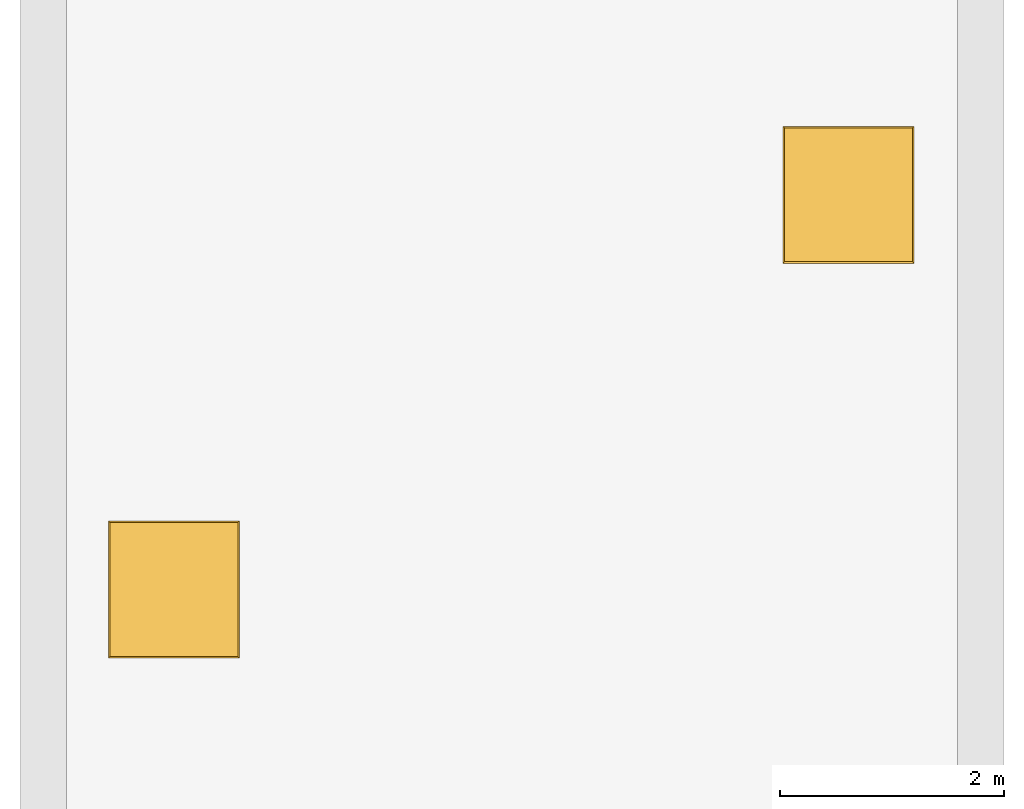
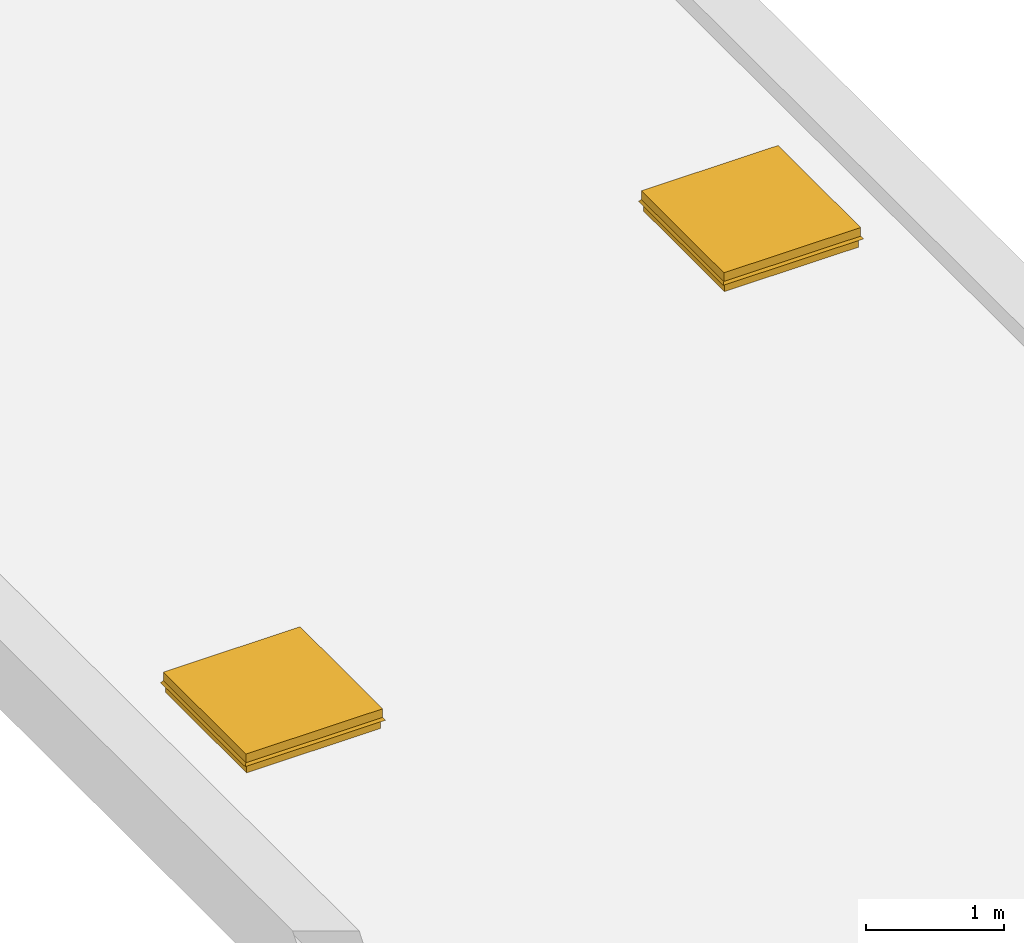
# One storey, part 2 of 2: 2 windows.
"""IFC2X3 building model written with IfcOpenShell, lengths in metres."""

from ifc_helpers import new_model, entity, si_unit, converted_unit, derived_unit, direction, frame, origin, place, context, subcontext, project, spatial, faceted_brep, source, transform, mapped, material, material_list, type_object, type_shapes, element, save


model = new_model("IFC2X3")

# Units and contexts
model_context = context("Model", 3, precision=1e-05, world=origin(), true_north=direction((6.12303176911189e-17, 1.0)))
body_context = subcontext(model_context, "Body", "Model", "MODEL_VIEW")
ifc_project = project(units=[derived_unit("USERDEFINED", [(si_unit("LENGTHUNIT", "METRE"), -2), (si_unit("TIMEUNIT", "SECOND"), -2), (si_unit("MASSUNIT", "GRAM", prefix="KILO"), 1)]), si_unit("FREQUENCYUNIT", "HERTZ"), si_unit("LENGTHUNIT", "METRE"), si_unit("ILLUMINANCEUNIT", "LUX"), derived_unit("LINEARVELOCITYUNIT", [(si_unit("TIMEUNIT", "SECOND"), -1), (si_unit("LENGTHUNIT", "METRE"), 1)]), si_unit("POWERUNIT", "WATT"), si_unit("LUMINOUSINTENSITYUNIT", "CANDELA"), si_unit("AREAUNIT", "SQUARE_METRE"), si_unit("VOLUMEUNIT", "CUBIC_METRE"), si_unit("ELECTRICVOLTAGEUNIT", "VOLT"), si_unit("PRESSUREUNIT", "PASCAL"), converted_unit("PLANEANGLEUNIT", "DEGREE", entity("IfcRatioMeasure", 0.0174532925199433), si_unit("PLANEANGLEUNIT", "RADIAN"), dimensions=[0, 0, 0, 0, 0, 0, 0]), si_unit("THERMODYNAMICTEMPERATUREUNIT", "DEGREE_CELSIUS"), si_unit("MASSUNIT", "GRAM", prefix="KILO"), derived_unit("VOLUMETRICFLOWRATEUNIT", [(si_unit("LENGTHUNIT", "METRE"), 3), (si_unit("TIMEUNIT", "SECOND"), -1)]), si_unit("TIMEUNIT", "SECOND"), si_unit("LUMINOUSFLUXUNIT", "LUMEN"), derived_unit("USERDEFINED", [(si_unit("LUMINOUSFLUXUNIT", "LUMEN"), 1), (si_unit("TIMEUNIT", "SECOND"), 3), (si_unit("MASSUNIT", "GRAM", prefix="KILO"), -1), (si_unit("LENGTHUNIT", "METRE"), -2)]), si_unit("FORCEUNIT", "NEWTON", prefix="KILO"), si_unit("ELECTRICCURRENTUNIT", "AMPERE"), derived_unit("THERMALTRANSMITTANCEUNIT", [(si_unit("TIMEUNIT", "SECOND"), -3), (si_unit("THERMODYNAMICTEMPERATUREUNIT", "KELVIN"), -1), (si_unit("MASSUNIT", "GRAM", prefix="KILO"), 1)])], contexts=[model_context])

# Site, building, storey
site_placement = place(None, origin())
site = spatial("IfcSite", under=ifc_project, at=site_placement, CompositionType="ELEMENT")
building_placement = place(site_placement, origin())
building = spatial("IfcBuilding", under=site, at=building_placement, CompositionType="ELEMENT")
storey_placement = place(building_placement, frame((0.0, 0.0, 6.0)))
storey = spatial("IfcBuildingStorey", under=building, at=storey_placement, Name="Roof", CompositionType="ELEMENT", Elevation=6.00000000000039)

# Windows
ifc_material_1 = material(Name="Metal - Bronze, Light Brush")
ifc_material_2 = material(Name="Glass")
ifc_material_list_1 = material_list([ifc_material_1, ifc_material_2])
ifc_material_list_2 = material_list([ifc_material_1, ifc_material_2])
window_style = type_object("IfcWindowStyle", Name="1180 x 1170mm", ConstructionType="OTHER_CONSTRUCTION", OperationType="NOTDEFINED", ParameterTakesPrecedence=False, Sizeable=False, material=ifc_material_list_2)
shared_shape = source(origin(), body_context, "Body", "Brep", [
    faceted_brep([(0.235390073027754, 0.351054098811972, 4.1146), (0.235390073027754, 0.351054098811972, 4.2416), (-0.793709926972272, 0.351054098811972, 4.2416), (-0.793709926972272, 0.351054098811972, 4.1146), (0.279840073027754, 0.395504098811972, 4.267), (0.279840073027754, 0.395504098811971, 4.1146), (-0.838159926972271, 0.395504098811972, 4.1146), (-0.838159926972271, 0.395504098811972, 4.267), (0.279840073027754, -0.774495901188029, 4.267), (0.279840073027754, -0.774495901188029, 4.1146), (0.254440073027754, -0.749095901188028, 4.2416), (0.254440073027754, -0.749095901188028, 4.267), (0.254440073027754, 0.370104098811971, 4.267), (0.254440073027754, 0.370104098811971, 4.2416), (-0.812759926972271, -0.749095901188028, 4.2416), (-0.812759926972271, -0.749095901188028, 4.267), (-0.793709926972272, -0.730045901188029, 4.1146), (-0.838159926972271, -0.774495901188029, 4.1146), (0.235390073027754, -0.730045901188029, 4.2416), (0.235390073027754, -0.730045901188029, 4.1146), (-0.838159926972271, -0.774495901188029, 4.267), (-0.812759926972271, 0.370104098811971, 4.2416), (-0.812759926972271, 0.370104098811971, 4.267), (-0.793709926972272, -0.730045901188029, 4.2416)], [[[0, 1, 2, 3]], [[4, 5, 6, 7]], [[8, 9, 5, 4]], [[10, 11, 12, 13]], [[14, 15, 11, 10]], [[6, 3, 16, 17]], [[18, 10, 13, 1]], [[11, 8, 4, 12]], [[9, 19, 0, 5]], [[7, 6, 17, 20]], [[15, 20, 8, 11]], [[21, 22, 15, 14]], [[2, 21, 14, 23]], [[19, 18, 1, 0]], [[5, 0, 3, 6]], [[3, 2, 23, 16]], [[22, 7, 20, 15]], [[1, 13, 21, 2]], [[17, 16, 19, 9]], [[13, 12, 22, 21]], [[23, 14, 10, 18]], [[12, 4, 7, 22]], [[16, 23, 18, 19]], [[20, 17, 9, 8]]]),
    faceted_brep([(-0.844509926972236, 0.401854098811971, 4.21419785269062), (-0.860227152974318, 0.417571324814053, 4.19175132770423), (0.301907299029799, 0.417571324814053, 4.19175132770423), (0.286190073027718, 0.401854098811971, 4.21419785269062), (-0.850859926972236, 0.408204098811971, 4.267), (-0.850859926972236, 0.408204098811971, 4.2924), (0.292540073027718, 0.408204098811971, 4.2924), (0.292540073027718, 0.408204098811971, 4.267), (0.292540073027718, 0.408204098811971, 4.2162), (0.292540073027718, -0.787195901188019, 4.267), (0.292540073027718, -0.787195901188019, 4.2162), (0.254440073027717, -0.749095901188018, 4.2924), (0.254440073027717, -0.749095901188018, 4.267), (-0.812759926972235, -0.749095901188018, 4.267), (-0.812759926972235, -0.749095901188018, 4.2924), (0.279840073027739, -0.77449590118804, 4.267), (-0.838159926972258, -0.77449590118804, 4.267), (-0.844509926972236, -0.780845901188019, 4.267), (-0.844509926972236, 0.401854098811971, 4.267), (-0.838159926972258, 0.395504098811992, 4.267), (0.292540073027718, -0.787195901188019, 4.2924), (-0.850859926972236, -0.787195901188019, 4.2924), (-0.850859926972236, -0.787195901188019, 4.267), (-0.860227152974318, -0.796563127190101, 4.19175132770423), (-0.865428768455553, -0.801764742671336, 4.19539353807506), (-0.865428768455553, 0.422772940295288, 4.19539353807506), (0.279840073027739, 0.395504098811992, 4.267), (0.286190073027718, 0.401854098811971, 4.267), (0.286190073027718, -0.780845901188019, 4.267), (0.307108914511034, -0.801764742671336, 4.19539353807506), (-0.850859926972236, -0.787195901188019, 4.2162), (0.286190073027718, -0.780845901188019, 4.21419785269062), (0.301907299029799, -0.796563127190101, 4.19175132770423), (-0.844509926972236, -0.780845901188019, 4.21419785269062), (0.307108914511034, 0.422772940295288, 4.19539353807506), (-0.812759926972235, 0.37010409881197, 4.267), (-0.850859926972236, 0.408204098811971, 4.2162), (0.254440073027717, 0.37010409881197, 4.267), (0.254440073027717, 0.37010409881197, 4.2924), (-0.812759926972235, 0.37010409881197, 4.2924)], [[[0, 1, 2, 3]], [[4, 5, 6, 7]], [[8, 7, 9, 10]], [[11, 12, 13, 14]], [[12, 15, 16, 13]], [[16, 17, 18, 19]], [[9, 20, 21, 22]], [[23, 24, 25, 1]], [[26, 27, 28, 15]], [[19, 18, 27, 26]], [[29, 10, 30, 24]], [[31, 32, 23, 33]], [[17, 33, 0, 18]], [[1, 25, 34, 2]], [[13, 16, 19, 35]], [[3, 2, 32, 31]], [[2, 34, 29, 32]], [[7, 6, 20, 9]], [[25, 36, 8, 34]], [[37, 26, 15, 12]], [[24, 30, 36, 25]], [[10, 9, 22, 30]], [[32, 29, 24, 23]], [[34, 8, 10, 29]], [[6, 38, 11, 20]], [[21, 14, 39, 5]], [[5, 39, 38, 6]], [[22, 21, 5, 4]], [[30, 22, 4, 36]], [[18, 0, 3, 27]], [[33, 23, 1, 0]], [[20, 11, 14, 21]], [[39, 35, 37, 38]], [[28, 31, 33, 17]], [[27, 3, 31, 28]], [[15, 28, 17, 16]], [[38, 37, 12, 11]], [[36, 4, 7, 8]], [[35, 19, 26, 37]], [[14, 13, 35, 39]]]),
    faceted_brep([(0.254440073027753, 0.37010409881193, 4.2924), (0.254440073027753, -0.749095901188029, 4.2924), (0.254440073027753, -0.749095901188029, 4.28605), (0.254440073027753, 0.37010409881193, 4.28605), (-0.812759926972291, -0.749095901188028, 4.2924), (-0.812759926972291, 0.37010409881193, 4.2924), (-0.812759926972291, 0.37010409881193, 4.28605), (-0.812759926972291, -0.749095901188028, 4.28605)], [[[0, 1, 2, 3]], [[4, 5, 6, 7]], [[1, 0, 5, 4]], [[5, 0, 3, 6]], [[2, 7, 6, 3]], [[1, 4, 7, 2]]]),
])
type_shapes(window_style, [shared_shape])
window_1_placement = place(storey_placement, frame((1.65515992697227, -10.475504098812, -3.65760000000018)))
element("IfcWindow", 1, at=window_1_placement, inside=storey, type_object=window_style, material=ifc_material_list_1, Name="M_Skylight:1180 x 1170mm", ObjectType="1180 x 1170mm", OverallHeight=0.634800000000001, OverallWidth=1.17253768296659, context=body_context, shape_type="MappedRepresentation", body=[
    mapped(shared_shape, transform((0.0, 0.0, 0.0), scale=1.0)),
])
ifc_material_list_3 = material_list([ifc_material_1, ifc_material_2])
window_2_placement = place(storey_placement, frame((7.68815992697228, -6.94550409881198, -3.65760000000018)))
element("IfcWindow", 2, at=window_2_placement, inside=storey, type_object=window_style, material=ifc_material_list_3, Name="M_Skylight:1180 x 1170mm", ObjectType="1180 x 1170mm", OverallHeight=0.634800000000001, OverallWidth=1.17253768296659, context=body_context, shape_type="MappedRepresentation", body=[
    mapped(shared_shape, transform((0.0, 0.0, 0.0), scale=1.0)),
])

save(model, "model.ifc")
